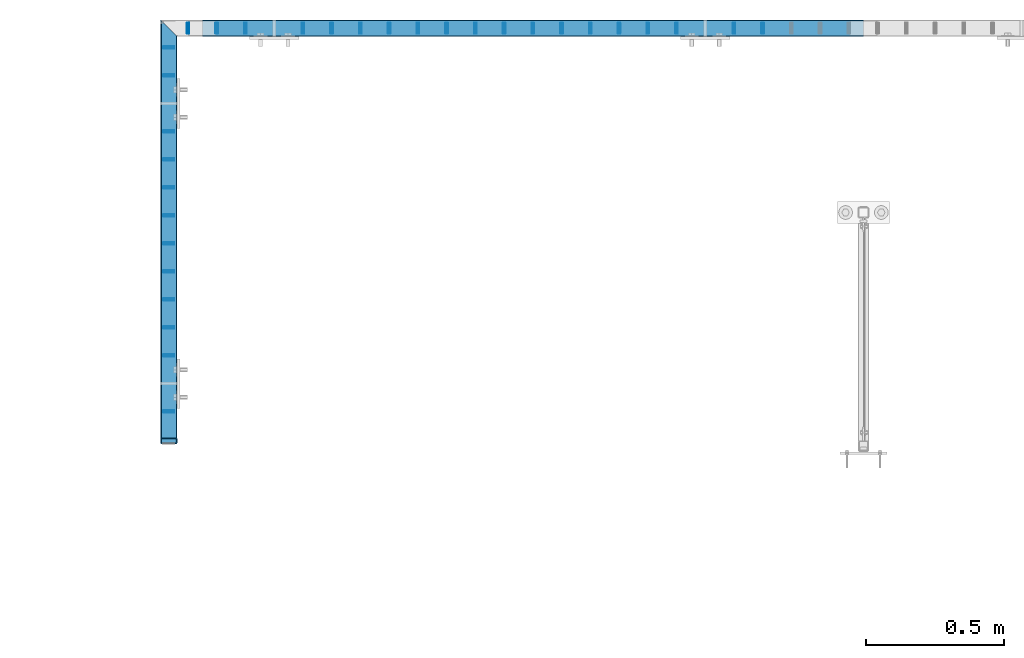
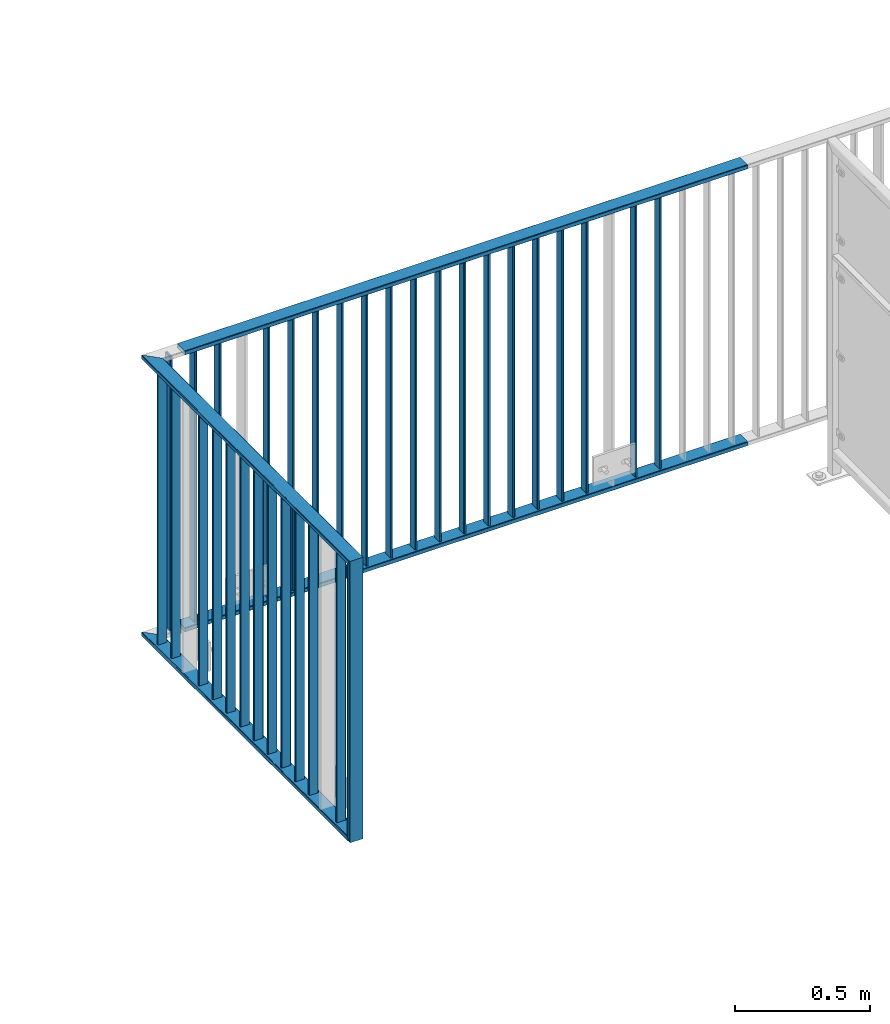
# One storey, part 14 of 156: 36 beams, 2 elements without a shape of their own.
"""IFC2X3 building model written with IfcOpenShell, lengths in millimetres."""

from ifc_helpers import new_model, si_unit, frame, origin_with_axes, origin_2d_with_axis, place, context, subcontext, project, spatial, hollow_rectangle, extrude, clip, halfspace, material, type_object, element, aggregate, save


model = new_model("IFC2X3")

# Units and contexts
model_context = context("Model", 3, precision=1e-05, world=origin_with_axes())
body_context = subcontext(model_context, "Body", "Model", "MODEL_VIEW")
ifc_project = project(units=[si_unit("LENGTHUNIT", "METRE", prefix="MILLI"), si_unit("AREAUNIT", "SQUARE_METRE"), si_unit("VOLUMEUNIT", "CUBIC_METRE"), si_unit("MASSUNIT", "GRAM", prefix="KILO"), si_unit("TIMEUNIT", "SECOND"), si_unit("PLANEANGLEUNIT", "RADIAN"), si_unit("SOLIDANGLEUNIT", "STERADIAN"), si_unit("THERMODYNAMICTEMPERATUREUNIT", "DEGREE_CELSIUS"), si_unit("LUMINOUSINTENSITYUNIT", "LUMEN")], contexts=[model_context])

# Site, building, storey
site_placement = place(None, origin_with_axes())
site = spatial("IfcSite", under=ifc_project, at=site_placement, CompositionType="ELEMENT")
building_placement = place(site_placement, origin_with_axes())
building = spatial("IfcBuilding", under=site, at=building_placement, Name="Undefined", CompositionType="ELEMENT")
storey_placement = place(building_placement, origin_with_axes())
storey = spatial("IfcBuildingStorey", under=building, at=storey_placement, Name="Undefined", CompositionType="ELEMENT", Elevation=0.0)

# Assembly, beam
assembly_1_placement = place(storey_placement, origin_with_axes())
assembly_1 = element("IfcElementAssembly", 1, at=assembly_1_placement, inside=storey, AssemblyPlace="NOTDEFINED", PredefinedType="RIGID_FRAME")
ifc_material = material(Name="STEEL/S235JR")
beam_type_1 = type_object("IfcBeamType", Name="K60/20/2", PredefinedType="NOTDEFINED")
beam_1_placement = place(assembly_1_placement, frame((24399.9535961914, 24057.9916132584, 2740.0), z_axis=(0.0, -1.0, 0.0), x_axis=(-1.0, 0.0, 0.0)))
beam_1 = element("IfcBeam", 2, at=beam_1_placement, type_object=beam_type_1, material=ifc_material, ObjectType="K60/20/2", context=body_context, shape_type="SweptSolid", body=[
    extrude(hollow_rectangle(XDim=20.0, YDim=60.0, WallThickness=2.0, InnerFilletRadius=2.0, OuterFilletRadius=4.0, at=origin_2d_with_axis()), frame((2402.81, 0.0, 0.0), z_axis=(-1.0, 0.0, 0.0), x_axis=(0.0, -1.0, 0.0)), (0.0, 0.0, 1.0), 2402.81),
])

# Assembly, beams
assembly_2_placement = place(storey_placement, origin_with_axes())
assembly_2 = element("IfcElementAssembly", 3, at=assembly_2_placement, inside=storey, AssemblyPlace="NOTDEFINED", PredefinedType="RIGID_FRAME")
beam_2_placement = place(assembly_2_placement, frame((21875.0005187988, 22558.0012658527, 4000.0), z_axis=(1.0, 0.0, 0.0), x_axis=(0.0, 0.0, -1.0)))
beam_2 = element("IfcBeam", 4, at=beam_2_placement, type_object=beam_type_1, material=ifc_material, ObjectType="K60/20/2", context=body_context, shape_type="Clipping", body=[
    clip(clip(extrude(hollow_rectangle(XDim=20.0, YDim=60.0, WallThickness=2.0, InnerFilletRadius=2.0, OuterFilletRadius=4.0, at=origin_2d_with_axis()), frame((1280.2, 0.0, 0.0), z_axis=(-1.0, 0.0, 0.0), x_axis=(0.0, -1.0, 0.0)), (0.0, 0.0, 1.0), 1290.4), halfspace(frame((1270.0, -10.0, 0.0), z_axis=(0.707106781186548, 0.707106781186548, 0.0), x_axis=(0.0, 0.0, 1.0)), False)), halfspace(frame((20.0, 10.0, 0.0), z_axis=(-0.707106781186548, 0.707106781186548, 0.0), x_axis=(0.0, 0.0, 1.0)), False)),
])
beam_3_placement = place(assembly_2_placement, frame((21874.9983520508, 24031.4403835157, 2740.0), z_axis=(1.0, 0.0, 0.0), x_axis=(0.0, -1.0, 0.0)))
beam_3 = element("IfcBeam", 5, at=beam_3_placement, type_object=beam_type_1, material=ifc_material, ObjectType="K60/20/2", context=body_context, shape_type="Clipping", body=[
    clip(clip(extrude(hollow_rectangle(XDim=20.0, YDim=60.0, WallThickness=2.0, InnerFilletRadius=2.0, OuterFilletRadius=4.0, at=origin_2d_with_axis()), frame((1513.83911766303, 0.0, 0.0), z_axis=(-1.0, 0.0, 0.0), x_axis=(0.0, -1.0, 0.0)), (0.0, 0.0, 1.0), 1580.79), halfspace(frame((1483.43911766303, 10.0, 0.002166748046875), z_axis=(-0.707106781186548, 0.707106781186548, 0.0), x_axis=(0.0, 0.0, 1.0)), True)), halfspace(frame((3.44877025730966, 0.0, 30.0), z_axis=(-0.707106781186548, 0.0, 0.707106781186548), x_axis=(0.0, -1.0, 0.0)), False)),
])

# Beam
beam_4_placement = place(assembly_1_placement, frame((24399.9535961914, 24057.9916132584, 3990.0), z_axis=(0.0, -1.0, 0.0), x_axis=(-1.0, 0.0, 0.0)))
beam_4 = element("IfcBeam", 6, at=beam_4_placement, type_object=beam_type_1, material=ifc_material, ObjectType="K60/20/2", context=body_context, shape_type="SweptSolid", body=[
    extrude(hollow_rectangle(XDim=20.0, YDim=60.0, WallThickness=2.0, InnerFilletRadius=2.0, OuterFilletRadius=4.0, at=origin_2d_with_axis()), frame((2402.81, 0.0, 0.0), z_axis=(-1.0, 0.0, 0.0), x_axis=(0.0, -1.0, 0.0)), (0.0, 0.0, 1.0), 2402.81),
])

beam_5_placement = place(assembly_2_placement, frame((21874.9983520508, 24031.4403835157, 3990.0), z_axis=(1.0, 0.0, 0.0), x_axis=(0.0, -1.0, 0.0)))
beam_5 = element("IfcBeam", 7, at=beam_5_placement, type_object=beam_type_1, material=ifc_material, ObjectType="K60/20/2", context=body_context, shape_type="Clipping", body=[
    clip(clip(extrude(hollow_rectangle(XDim=20.0, YDim=60.0, WallThickness=2.0, InnerFilletRadius=2.0, OuterFilletRadius=4.0, at=origin_2d_with_axis()), frame((1513.83911766303, 0.0, 0.0), z_axis=(-1.0, 0.0, 0.0), x_axis=(0.0, -1.0, 0.0)), (0.0, 0.0, 1.0), 1580.79), halfspace(frame((1463.43911766303, 10.0, 0.002166748046875), z_axis=(-0.707106781186548, -0.707106781186548, 0.0), x_axis=(0.0, 0.0, 1.0)), True)), halfspace(frame((-56.5512297426903, 0.0, -30.0), z_axis=(0.707106781186548, 0.0, -0.707106781186548), x_axis=(0.0, -1.0, 0.0)), True)),
])

beam_type_2 = type_object("IfcBeamType", Name="K40/10/1.5", PredefinedType="NOTDEFINED")
beam_6_placement = place(assembly_2_placement, frame((21874.9983597497, 22664.8503835168, 3980.00000000003), z_axis=(1.0, 0.0, 0.0), x_axis=(0.0, 0.0, -1.0)))
beam_6 = element("IfcBeam", 8, at=beam_6_placement, type_object=beam_type_2, material=ifc_material, ObjectType="K40/10/1.5", context=body_context, shape_type="Clipping", body=[
    clip(clip(extrude(hollow_rectangle(XDim=10.0, YDim=40.0, WallThickness=1.5, InnerFilletRadius=1.5, OuterFilletRadius=3.0, at=origin_2d_with_axis()), frame((1237.00000000003, 0.0, 0.0), z_axis=(-1.0, 0.0, 0.0), x_axis=(0.0, -1.0, 0.0)), (0.0, 0.0, 1.0), 1244.0), halfspace(frame((1237.00000000003, 3.63803898150218, 46.7940496082883), z_axis=(1.0, 0.0, 0.0), x_axis=(0.0, -0.758923924280425, -0.65117929724063)), False)), halfspace(frame((-6.99999999997453, -3.63803898149854, 46.7940496082956), z_axis=(-1.0, 0.0, 0.0), x_axis=(0.0, 0.75892392428044, -0.651179297240612)), False)),
])

beam_7_placement = place(assembly_2_placement, frame((21874.9983597497, 22868.4103835168, 3980.00000000003), z_axis=(1.0, 0.0, 0.0), x_axis=(0.0, 0.0, -1.0)))
beam_7 = element("IfcBeam", 9, at=beam_7_placement, type_object=beam_type_2, material=ifc_material, ObjectType="K40/10/1.5", context=body_context, shape_type="Clipping", body=[
    clip(clip(extrude(hollow_rectangle(XDim=10.0, YDim=40.0, WallThickness=1.5, InnerFilletRadius=1.5, OuterFilletRadius=3.0, at=origin_2d_with_axis()), frame((1237.00000000003, 0.0, 0.0), z_axis=(-1.0, 0.0, 0.0), x_axis=(0.0, -1.0, 0.0)), (0.0, 0.0, 1.0), 1244.0), halfspace(frame((1237.00000000003, 3.63803898150218, 46.7940496082883), z_axis=(1.0, 0.0, 0.0), x_axis=(0.0, -0.758923924280425, -0.65117929724063)), False)), halfspace(frame((-6.99999999997453, -3.63803898149854, 46.7940496082956), z_axis=(-1.0, 0.0, 0.0), x_axis=(0.0, 0.75892392428044, -0.651179297240612)), False)),
])

beam_8_placement = place(assembly_2_placement, frame((21874.9983597497, 22970.1903835168, 3980.00000000003), z_axis=(1.0, 0.0, 0.0), x_axis=(0.0, 0.0, -1.0)))
beam_8 = element("IfcBeam", 10, at=beam_8_placement, type_object=beam_type_2, material=ifc_material, ObjectType="K40/10/1.5", context=body_context, shape_type="Clipping", body=[
    clip(clip(extrude(hollow_rectangle(XDim=10.0, YDim=40.0, WallThickness=1.5, InnerFilletRadius=1.5, OuterFilletRadius=3.0, at=origin_2d_with_axis()), frame((1237.00000000003, 0.0, 0.0), z_axis=(-1.0, 0.0, 0.0), x_axis=(0.0, -1.0, 0.0)), (0.0, 0.0, 1.0), 1244.0), halfspace(frame((1237.00000000003, 3.63803898150218, 46.7940496082883), z_axis=(1.0, 0.0, 0.0), x_axis=(0.0, -0.758923924280425, -0.65117929724063)), False)), halfspace(frame((-6.99999999997453, -3.63803898149854, 46.7940496082956), z_axis=(-1.0, 0.0, 0.0), x_axis=(0.0, 0.75892392428044, -0.651179297240612)), False)),
])

beam_9_placement = place(assembly_2_placement, frame((21874.9983597497, 23071.9703835168, 3980.00000000003), z_axis=(1.0, 0.0, 0.0), x_axis=(0.0, 0.0, -1.0)))
beam_9 = element("IfcBeam", 11, at=beam_9_placement, type_object=beam_type_2, material=ifc_material, ObjectType="K40/10/1.5", context=body_context, shape_type="Clipping", body=[
    clip(clip(extrude(hollow_rectangle(XDim=10.0, YDim=40.0, WallThickness=1.5, InnerFilletRadius=1.5, OuterFilletRadius=3.0, at=origin_2d_with_axis()), frame((1237.00000000003, 0.0, 0.0), z_axis=(-1.0, 0.0, 0.0), x_axis=(0.0, -1.0, 0.0)), (0.0, 0.0, 1.0), 1244.0), halfspace(frame((1237.00000000003, 3.63803898150218, 46.7940496082883), z_axis=(1.0, 0.0, 0.0), x_axis=(0.0, -0.758923924280425, -0.65117929724063)), False)), halfspace(frame((-6.99999999997453, -3.63803898149854, 46.7940496082956), z_axis=(-1.0, 0.0, 0.0), x_axis=(0.0, 0.75892392428044, -0.651179297240612)), False)),
])

beam_10_placement = place(assembly_2_placement, frame((21874.9983597497, 23173.7503835168, 3980.00000000003), z_axis=(1.0, 0.0, 0.0), x_axis=(0.0, 0.0, -1.0)))
beam_10 = element("IfcBeam", 12, at=beam_10_placement, type_object=beam_type_2, material=ifc_material, ObjectType="K40/10/1.5", context=body_context, shape_type="Clipping", body=[
    clip(clip(extrude(hollow_rectangle(XDim=10.0, YDim=40.0, WallThickness=1.5, InnerFilletRadius=1.5, OuterFilletRadius=3.0, at=origin_2d_with_axis()), frame((1237.00000000003, 0.0, 0.0), z_axis=(-1.0, 0.0, 0.0), x_axis=(0.0, -1.0, 0.0)), (0.0, 0.0, 1.0), 1244.0), halfspace(frame((1237.00000000003, 3.63803898150218, 46.7940496082883), z_axis=(1.0, 0.0, 0.0), x_axis=(0.0, -0.758923924280425, -0.65117929724063)), False)), halfspace(frame((-6.99999999997453, -3.63803898149854, 46.7940496082956), z_axis=(-1.0, 0.0, 0.0), x_axis=(0.0, 0.75892392428044, -0.651179297240612)), False)),
])

beam_11_placement = place(assembly_2_placement, frame((21874.9983597497, 23275.5303835168, 3980.00000000003), z_axis=(1.0, 0.0, 0.0), x_axis=(0.0, 0.0, -1.0)))
beam_11 = element("IfcBeam", 13, at=beam_11_placement, type_object=beam_type_2, material=ifc_material, ObjectType="K40/10/1.5", context=body_context, shape_type="Clipping", body=[
    clip(clip(extrude(hollow_rectangle(XDim=10.0, YDim=40.0, WallThickness=1.5, InnerFilletRadius=1.5, OuterFilletRadius=3.0, at=origin_2d_with_axis()), frame((1237.00000000003, 0.0, 0.0), z_axis=(-1.0, 0.0, 0.0), x_axis=(0.0, -1.0, 0.0)), (0.0, 0.0, 1.0), 1244.0), halfspace(frame((1237.00000000003, 3.63803898150218, 46.7940496082883), z_axis=(1.0, 0.0, 0.0), x_axis=(0.0, -0.758923924280425, -0.65117929724063)), False)), halfspace(frame((-6.99999999997453, -3.63803898149854, 46.7940496082956), z_axis=(-1.0, 0.0, 0.0), x_axis=(0.0, 0.75892392428044, -0.651179297240612)), False)),
])

beam_12_placement = place(assembly_2_placement, frame((21874.9983597497, 23377.3103835168, 3980.00000000003), z_axis=(1.0, 0.0, 0.0), x_axis=(0.0, 0.0, -1.0)))
beam_12 = element("IfcBeam", 14, at=beam_12_placement, type_object=beam_type_2, material=ifc_material, ObjectType="K40/10/1.5", context=body_context, shape_type="Clipping", body=[
    clip(clip(extrude(hollow_rectangle(XDim=10.0, YDim=40.0, WallThickness=1.5, InnerFilletRadius=1.5, OuterFilletRadius=3.0, at=origin_2d_with_axis()), frame((1237.00000000003, 0.0, 0.0), z_axis=(-1.0, 0.0, 0.0), x_axis=(0.0, -1.0, 0.0)), (0.0, 0.0, 1.0), 1244.0), halfspace(frame((1237.00000000003, 3.63803898150218, 46.7940496082883), z_axis=(1.0, 0.0, 0.0), x_axis=(0.0, -0.758923924280425, -0.65117929724063)), False)), halfspace(frame((-6.99999999997453, -3.63803898149854, 46.7940496082956), z_axis=(-1.0, 0.0, 0.0), x_axis=(0.0, 0.75892392428044, -0.651179297240612)), False)),
])

beam_13_placement = place(assembly_2_placement, frame((21874.9983597497, 23479.0903835168, 3980.00000000003), z_axis=(1.0, 0.0, 0.0), x_axis=(0.0, 0.0, -1.0)))
beam_13 = element("IfcBeam", 15, at=beam_13_placement, type_object=beam_type_2, material=ifc_material, ObjectType="K40/10/1.5", context=body_context, shape_type="Clipping", body=[
    clip(clip(extrude(hollow_rectangle(XDim=10.0, YDim=40.0, WallThickness=1.5, InnerFilletRadius=1.5, OuterFilletRadius=3.0, at=origin_2d_with_axis()), frame((1237.00000000003, 0.0, 0.0), z_axis=(-1.0, 0.0, 0.0), x_axis=(0.0, -1.0, 0.0)), (0.0, 0.0, 1.0), 1244.0), halfspace(frame((1237.00000000003, 3.63803898150218, 46.7940496082883), z_axis=(1.0, 0.0, 0.0), x_axis=(0.0, -0.758923924280425, -0.65117929724063)), False)), halfspace(frame((-6.99999999997453, -3.63803898149854, 46.7940496082956), z_axis=(-1.0, 0.0, 0.0), x_axis=(0.0, 0.75892392428044, -0.651179297240612)), False)),
])

beam_14_placement = place(assembly_2_placement, frame((21874.9983597497, 23580.8703835168, 3980.00000000003), z_axis=(1.0, 0.0, 0.0), x_axis=(0.0, 0.0, -1.0)))
beam_14 = element("IfcBeam", 16, at=beam_14_placement, type_object=beam_type_2, material=ifc_material, ObjectType="K40/10/1.5", context=body_context, shape_type="Clipping", body=[
    clip(clip(extrude(hollow_rectangle(XDim=10.0, YDim=40.0, WallThickness=1.5, InnerFilletRadius=1.5, OuterFilletRadius=3.0, at=origin_2d_with_axis()), frame((1237.00000000003, 0.0, 0.0), z_axis=(-1.0, 0.0, 0.0), x_axis=(0.0, -1.0, 0.0)), (0.0, 0.0, 1.0), 1244.0), halfspace(frame((1237.00000000003, 3.63803898150218, 46.7940496082883), z_axis=(1.0, 0.0, 0.0), x_axis=(0.0, -0.758923924280425, -0.65117929724063)), False)), halfspace(frame((-6.99999999997453, -3.63803898149854, 46.7940496082956), z_axis=(-1.0, 0.0, 0.0), x_axis=(0.0, 0.75892392428044, -0.651179297240612)), False)),
])

beam_15_placement = place(assembly_2_placement, frame((21874.9983597497, 23682.6503835168, 3980.00000000003), z_axis=(1.0, 0.0, 0.0), x_axis=(0.0, 0.0, -1.0)))
beam_15 = element("IfcBeam", 17, at=beam_15_placement, type_object=beam_type_2, material=ifc_material, ObjectType="K40/10/1.5", context=body_context, shape_type="Clipping", body=[
    clip(clip(extrude(hollow_rectangle(XDim=10.0, YDim=40.0, WallThickness=1.5, InnerFilletRadius=1.5, OuterFilletRadius=3.0, at=origin_2d_with_axis()), frame((1237.00000000003, 0.0, 0.0), z_axis=(-1.0, 0.0, 0.0), x_axis=(0.0, -1.0, 0.0)), (0.0, 0.0, 1.0), 1244.0), halfspace(frame((1237.00000000003, 3.63803898150218, 46.7940496082883), z_axis=(1.0, 0.0, 0.0), x_axis=(0.0, -0.758923924280425, -0.65117929724063)), False)), halfspace(frame((-6.99999999997453, -3.63803898149854, 46.7940496082956), z_axis=(-1.0, 0.0, 0.0), x_axis=(0.0, 0.75892392428044, -0.651179297240612)), False)),
])

beam_16_placement = place(assembly_1_placement, frame((22153.8485961914, 24057.9916132584, 3980.00000000003), z_axis=(0.0, -1.0, 0.0), x_axis=(0.0, 0.0, -1.0)))
beam_16 = element("IfcBeam", 18, at=beam_16_placement, type_object=beam_type_2, material=ifc_material, ObjectType="K40/10/1.5", context=body_context, shape_type="Clipping", body=[
    clip(clip(extrude(hollow_rectangle(XDim=10.0, YDim=40.0, WallThickness=1.5, InnerFilletRadius=1.5, OuterFilletRadius=3.0, at=origin_2d_with_axis()), frame((1237.00000000003, 0.0, 0.0), z_axis=(-1.0, 0.0, 0.0), x_axis=(0.0, -1.0, 0.0)), (0.0, 0.0, 1.0), 1244.0), halfspace(frame((1237.00000000003, 4.34248751949781, 47.3810900558092), z_axis=(1.0, 0.0, 0.0), x_axis=(0.0, -0.768354814194188, -0.640024124158313)), False)), halfspace(frame((-6.99999999997453, -4.34248751950508, 47.3810900558092), z_axis=(-1.0, 0.0, 0.0), x_axis=(0.0, 0.7683548141934, -0.640024124159258)), False)),
])

beam_17_placement = place(assembly_1_placement, frame((23720.8985961914, 24057.9916132584, 3980.00000000003), z_axis=(0.0, -1.0, 0.0), x_axis=(0.0, 0.0, -1.0)))
beam_17 = element("IfcBeam", 19, at=beam_17_placement, type_object=beam_type_2, material=ifc_material, ObjectType="K40/10/1.5", context=body_context, shape_type="Clipping", body=[
    clip(clip(extrude(hollow_rectangle(XDim=10.0, YDim=40.0, WallThickness=1.5, InnerFilletRadius=1.5, OuterFilletRadius=3.0, at=origin_2d_with_axis()), frame((1237.00000000003, 0.0, 0.0), z_axis=(-1.0, 0.0, 0.0), x_axis=(0.0, -1.0, 0.0)), (0.0, 0.0, 1.0), 1244.0), halfspace(frame((1237.00000000003, 4.34248751949781, 47.3810900558092), z_axis=(1.0, 0.0, 0.0), x_axis=(0.0, -0.768354814194188, -0.640024124158313)), False)), halfspace(frame((-6.99999999997453, -4.34248751950508, 47.3810900558092), z_axis=(-1.0, 0.0, 0.0), x_axis=(0.0, 0.7683548141934, -0.640024124159258)), False)),
])

beam_18_placement = place(assembly_1_placement, frame((22049.3785961914, 24057.9916132584, 3980.00000000003), z_axis=(0.0, -1.0, 0.0), x_axis=(0.0, 0.0, -1.0)))
beam_18 = element("IfcBeam", 20, at=beam_18_placement, type_object=beam_type_2, material=ifc_material, ObjectType="K40/10/1.5", context=body_context, shape_type="Clipping", body=[
    clip(clip(extrude(hollow_rectangle(XDim=10.0, YDim=40.0, WallThickness=1.5, InnerFilletRadius=1.5, OuterFilletRadius=3.0, at=origin_2d_with_axis()), frame((1237.00000000003, 0.0, 0.0), z_axis=(-1.0, 0.0, 0.0), x_axis=(0.0, -1.0, 0.0)), (0.0, 0.0, 1.0), 1244.0), halfspace(frame((1237.00000000003, 4.34248751949781, 47.3810900558092), z_axis=(1.0, 0.0, 0.0), x_axis=(0.0, -0.763991285051099, -0.645226562043109)), False)), halfspace(frame((-6.99999999997453, -4.34248751950508, 47.3810900558092), z_axis=(-1.0, 0.0, 0.0), x_axis=(0.0, 0.763991285051099, -0.645226562043109)), False)),
])

beam_19_placement = place(assembly_1_placement, frame((22362.7885961914, 24057.9916132584, 3980.00000000003), z_axis=(0.0, -1.0, 0.0), x_axis=(0.0, 0.0, -1.0)))
beam_19 = element("IfcBeam", 21, at=beam_19_placement, type_object=beam_type_2, material=ifc_material, ObjectType="K40/10/1.5", context=body_context, shape_type="Clipping", body=[
    clip(clip(extrude(hollow_rectangle(XDim=10.0, YDim=40.0, WallThickness=1.5, InnerFilletRadius=1.5, OuterFilletRadius=3.0, at=origin_2d_with_axis()), frame((1237.00000000003, 0.0, 0.0), z_axis=(-1.0, 0.0, 0.0), x_axis=(0.0, -1.0, 0.0)), (0.0, 0.0, 1.0), 1244.0), halfspace(frame((1237.00000000003, 4.34248751949781, 47.3810900558092), z_axis=(1.0, 0.0, 0.0), x_axis=(0.0, -0.768354814194188, -0.640024124158313)), False)), halfspace(frame((-6.99999999997453, -4.34248751950508, 47.3810900558092), z_axis=(-1.0, 0.0, 0.0), x_axis=(0.0, 0.7683548141934, -0.640024124159258)), False)),
])

beam_20_placement = place(assembly_1_placement, frame((22467.2585961914, 24057.9916132584, 3980.00000000003), z_axis=(0.0, -1.0, 0.0), x_axis=(0.0, 0.0, -1.0)))
beam_20 = element("IfcBeam", 22, at=beam_20_placement, type_object=beam_type_2, material=ifc_material, ObjectType="K40/10/1.5", context=body_context, shape_type="Clipping", body=[
    clip(clip(extrude(hollow_rectangle(XDim=10.0, YDim=40.0, WallThickness=1.5, InnerFilletRadius=1.5, OuterFilletRadius=3.0, at=origin_2d_with_axis()), frame((1237.00000000003, 0.0, 0.0), z_axis=(-1.0, 0.0, 0.0), x_axis=(0.0, -1.0, 0.0)), (0.0, 0.0, 1.0), 1244.0), halfspace(frame((1237.00000000003, 4.34248751949781, 47.3810900558092), z_axis=(1.0, 0.0, 0.0), x_axis=(0.0, -0.768354814194188, -0.640024124158313)), False)), halfspace(frame((-6.99999999997453, -4.34248751950508, 47.3810900558092), z_axis=(-1.0, 0.0, 0.0), x_axis=(0.0, 0.7683548141934, -0.640024124159258)), False)),
])

beam_21_placement = place(assembly_1_placement, frame((22571.7285961914, 24057.9916132584, 3980.00000000003), z_axis=(0.0, -1.0, 0.0), x_axis=(0.0, 0.0, -1.0)))
beam_21 = element("IfcBeam", 23, at=beam_21_placement, type_object=beam_type_2, material=ifc_material, ObjectType="K40/10/1.5", context=body_context, shape_type="Clipping", body=[
    clip(clip(extrude(hollow_rectangle(XDim=10.0, YDim=40.0, WallThickness=1.5, InnerFilletRadius=1.5, OuterFilletRadius=3.0, at=origin_2d_with_axis()), frame((1237.00000000003, 0.0, 0.0), z_axis=(-1.0, 0.0, 0.0), x_axis=(0.0, -1.0, 0.0)), (0.0, 0.0, 1.0), 1244.0), halfspace(frame((1237.00000000003, 4.34248751949781, 47.3810900558092), z_axis=(1.0, 0.0, 0.0), x_axis=(0.0, -0.768354814194188, -0.640024124158313)), False)), halfspace(frame((-6.99999999997453, -4.34248751950508, 47.3810900558092), z_axis=(-1.0, 0.0, 0.0), x_axis=(0.0, 0.7683548141934, -0.640024124159258)), False)),
])

beam_22_placement = place(assembly_1_placement, frame((22676.1985961914, 24057.9916132584, 3980.00000000003), z_axis=(0.0, -1.0, 0.0), x_axis=(0.0, 0.0, -1.0)))
beam_22 = element("IfcBeam", 24, at=beam_22_placement, type_object=beam_type_2, material=ifc_material, ObjectType="K40/10/1.5", context=body_context, shape_type="Clipping", body=[
    clip(clip(extrude(hollow_rectangle(XDim=10.0, YDim=40.0, WallThickness=1.5, InnerFilletRadius=1.5, OuterFilletRadius=3.0, at=origin_2d_with_axis()), frame((1237.00000000003, 0.0, 0.0), z_axis=(-1.0, 0.0, 0.0), x_axis=(0.0, -1.0, 0.0)), (0.0, 0.0, 1.0), 1244.0), halfspace(frame((1237.00000000003, 4.34248751949781, 47.3810900558092), z_axis=(1.0, 0.0, 0.0), x_axis=(0.0, -0.768354814194188, -0.640024124158313)), False)), halfspace(frame((-6.99999999997453, -4.34248751950508, 47.3810900558092), z_axis=(-1.0, 0.0, 0.0), x_axis=(0.0, 0.7683548141934, -0.640024124159258)), False)),
])

beam_23_placement = place(assembly_1_placement, frame((22780.6685961914, 24057.9916132584, 3980.00000000003), z_axis=(0.0, -1.0, 0.0), x_axis=(0.0, 0.0, -1.0)))
beam_23 = element("IfcBeam", 25, at=beam_23_placement, type_object=beam_type_2, material=ifc_material, ObjectType="K40/10/1.5", context=body_context, shape_type="Clipping", body=[
    clip(clip(extrude(hollow_rectangle(XDim=10.0, YDim=40.0, WallThickness=1.5, InnerFilletRadius=1.5, OuterFilletRadius=3.0, at=origin_2d_with_axis()), frame((1237.00000000003, 0.0, 0.0), z_axis=(-1.0, 0.0, 0.0), x_axis=(0.0, -1.0, 0.0)), (0.0, 0.0, 1.0), 1244.0), halfspace(frame((1237.00000000003, 4.34248751949781, 47.3810900558092), z_axis=(1.0, 0.0, 0.0), x_axis=(0.0, -0.768354814194188, -0.640024124158313)), False)), halfspace(frame((-6.99999999997453, -4.34248751950508, 47.3810900558092), z_axis=(-1.0, 0.0, 0.0), x_axis=(0.0, 0.7683548141934, -0.640024124159258)), False)),
])

beam_24_placement = place(assembly_1_placement, frame((22885.1385961914, 24057.9916132584, 3980.00000000003), z_axis=(0.0, -1.0, 0.0), x_axis=(0.0, 0.0, -1.0)))
beam_24 = element("IfcBeam", 26, at=beam_24_placement, type_object=beam_type_2, material=ifc_material, ObjectType="K40/10/1.5", context=body_context, shape_type="Clipping", body=[
    clip(clip(extrude(hollow_rectangle(XDim=10.0, YDim=40.0, WallThickness=1.5, InnerFilletRadius=1.5, OuterFilletRadius=3.0, at=origin_2d_with_axis()), frame((1237.00000000003, 0.0, 0.0), z_axis=(-1.0, 0.0, 0.0), x_axis=(0.0, -1.0, 0.0)), (0.0, 0.0, 1.0), 1244.0), halfspace(frame((1237.00000000003, 4.34248751949781, 47.3810900558092), z_axis=(1.0, 0.0, 0.0), x_axis=(0.0, -0.768354814194188, -0.640024124158313)), False)), halfspace(frame((-6.99999999997453, -4.34248751950508, 47.3810900558092), z_axis=(-1.0, 0.0, 0.0), x_axis=(0.0, 0.7683548141934, -0.640024124159258)), False)),
])

beam_25_placement = place(assembly_1_placement, frame((22989.6085961914, 24057.9916132584, 3980.00000000003), z_axis=(0.0, -1.0, 0.0), x_axis=(0.0, 0.0, -1.0)))
beam_25 = element("IfcBeam", 27, at=beam_25_placement, type_object=beam_type_2, material=ifc_material, ObjectType="K40/10/1.5", context=body_context, shape_type="Clipping", body=[
    clip(clip(extrude(hollow_rectangle(XDim=10.0, YDim=40.0, WallThickness=1.5, InnerFilletRadius=1.5, OuterFilletRadius=3.0, at=origin_2d_with_axis()), frame((1237.00000000003, 0.0, 0.0), z_axis=(-1.0, 0.0, 0.0), x_axis=(0.0, -1.0, 0.0)), (0.0, 0.0, 1.0), 1244.0), halfspace(frame((1237.00000000003, 4.34248751949781, 47.3810900558092), z_axis=(1.0, 0.0, 0.0), x_axis=(0.0, -0.768354814194188, -0.640024124158313)), False)), halfspace(frame((-6.99999999997453, -4.34248751950508, 47.3810900558092), z_axis=(-1.0, 0.0, 0.0), x_axis=(0.0, 0.7683548141934, -0.640024124159258)), False)),
])

beam_26_placement = place(assembly_1_placement, frame((23094.0785961914, 24057.9916132584, 3980.00000000003), z_axis=(0.0, -1.0, 0.0), x_axis=(0.0, 0.0, -1.0)))
beam_26 = element("IfcBeam", 28, at=beam_26_placement, type_object=beam_type_2, material=ifc_material, ObjectType="K40/10/1.5", context=body_context, shape_type="Clipping", body=[
    clip(clip(extrude(hollow_rectangle(XDim=10.0, YDim=40.0, WallThickness=1.5, InnerFilletRadius=1.5, OuterFilletRadius=3.0, at=origin_2d_with_axis()), frame((1237.00000000003, 0.0, 0.0), z_axis=(-1.0, 0.0, 0.0), x_axis=(0.0, -1.0, 0.0)), (0.0, 0.0, 1.0), 1244.0), halfspace(frame((1237.00000000003, 4.34248751949781, 47.3810900558092), z_axis=(1.0, 0.0, 0.0), x_axis=(0.0, -0.768354814194188, -0.640024124158313)), False)), halfspace(frame((-6.99999999997453, -4.34248751950508, 47.3810900558092), z_axis=(-1.0, 0.0, 0.0), x_axis=(0.0, 0.7683548141934, -0.640024124159258)), False)),
])

beam_27_placement = place(assembly_1_placement, frame((23198.5485961914, 24057.9916132584, 3980.00000000003), z_axis=(0.0, -1.0, 0.0), x_axis=(0.0, 0.0, -1.0)))
beam_27 = element("IfcBeam", 29, at=beam_27_placement, type_object=beam_type_2, material=ifc_material, ObjectType="K40/10/1.5", context=body_context, shape_type="Clipping", body=[
    clip(clip(extrude(hollow_rectangle(XDim=10.0, YDim=40.0, WallThickness=1.5, InnerFilletRadius=1.5, OuterFilletRadius=3.0, at=origin_2d_with_axis()), frame((1237.00000000003, 0.0, 0.0), z_axis=(-1.0, 0.0, 0.0), x_axis=(0.0, -1.0, 0.0)), (0.0, 0.0, 1.0), 1244.0), halfspace(frame((1237.00000000003, 4.34248751949781, 47.3810900558092), z_axis=(1.0, 0.0, 0.0), x_axis=(0.0, -0.768354814194188, -0.640024124158313)), False)), halfspace(frame((-6.99999999997453, -4.34248751950508, 47.3810900558092), z_axis=(-1.0, 0.0, 0.0), x_axis=(0.0, 0.7683548141934, -0.640024124159258)), False)),
])

beam_28_placement = place(assembly_1_placement, frame((23303.0185961914, 24057.9916132584, 3980.00000000003), z_axis=(0.0, -1.0, 0.0), x_axis=(0.0, 0.0, -1.0)))
beam_28 = element("IfcBeam", 30, at=beam_28_placement, type_object=beam_type_2, material=ifc_material, ObjectType="K40/10/1.5", context=body_context, shape_type="Clipping", body=[
    clip(clip(extrude(hollow_rectangle(XDim=10.0, YDim=40.0, WallThickness=1.5, InnerFilletRadius=1.5, OuterFilletRadius=3.0, at=origin_2d_with_axis()), frame((1237.00000000003, 0.0, 0.0), z_axis=(-1.0, 0.0, 0.0), x_axis=(0.0, -1.0, 0.0)), (0.0, 0.0, 1.0), 1244.0), halfspace(frame((1237.00000000003, 4.34248751949781, 47.3810900558092), z_axis=(1.0, 0.0, 0.0), x_axis=(0.0, -0.768354814194188, -0.640024124158313)), False)), halfspace(frame((-6.99999999997453, -4.34248751950508, 47.3810900558092), z_axis=(-1.0, 0.0, 0.0), x_axis=(0.0, 0.7683548141934, -0.640024124159258)), False)),
])

beam_29_placement = place(assembly_1_placement, frame((23407.4885961914, 24057.9916132584, 3980.00000000003), z_axis=(0.0, -1.0, 0.0), x_axis=(0.0, 0.0, -1.0)))
beam_29 = element("IfcBeam", 31, at=beam_29_placement, type_object=beam_type_2, material=ifc_material, ObjectType="K40/10/1.5", context=body_context, shape_type="Clipping", body=[
    clip(clip(extrude(hollow_rectangle(XDim=10.0, YDim=40.0, WallThickness=1.5, InnerFilletRadius=1.5, OuterFilletRadius=3.0, at=origin_2d_with_axis()), frame((1237.00000000003, 0.0, 0.0), z_axis=(-1.0, 0.0, 0.0), x_axis=(0.0, -1.0, 0.0)), (0.0, 0.0, 1.0), 1244.0), halfspace(frame((1237.00000000003, 4.34248751949781, 47.3810900558092), z_axis=(1.0, 0.0, 0.0), x_axis=(0.0, -0.768354814194188, -0.640024124158313)), False)), halfspace(frame((-6.99999999997453, -4.34248751950508, 47.3810900558092), z_axis=(-1.0, 0.0, 0.0), x_axis=(0.0, 0.7683548141934, -0.640024124159258)), False)),
])

beam_30_placement = place(assembly_1_placement, frame((23511.9585961914, 24057.9916132584, 3980.00000000003), z_axis=(0.0, -1.0, 0.0), x_axis=(0.0, 0.0, -1.0)))
beam_30 = element("IfcBeam", 32, at=beam_30_placement, type_object=beam_type_2, material=ifc_material, ObjectType="K40/10/1.5", context=body_context, shape_type="Clipping", body=[
    clip(clip(extrude(hollow_rectangle(XDim=10.0, YDim=40.0, WallThickness=1.5, InnerFilletRadius=1.5, OuterFilletRadius=3.0, at=origin_2d_with_axis()), frame((1237.00000000003, 0.0, 0.0), z_axis=(-1.0, 0.0, 0.0), x_axis=(0.0, -1.0, 0.0)), (0.0, 0.0, 1.0), 1244.0), halfspace(frame((1237.00000000003, 4.34248751949781, 47.3810900558092), z_axis=(1.0, 0.0, 0.0), x_axis=(0.0, -0.768354814194188, -0.640024124158313)), False)), halfspace(frame((-6.99999999997453, -4.34248751950508, 47.3810900558092), z_axis=(-1.0, 0.0, 0.0), x_axis=(0.0, 0.7683548141934, -0.640024124159258)), False)),
])

beam_31_placement = place(assembly_1_placement, frame((23616.4285961914, 24057.9916132584, 3980.00000000003), z_axis=(0.0, -1.0, 0.0), x_axis=(0.0, 0.0, -1.0)))
beam_31 = element("IfcBeam", 33, at=beam_31_placement, type_object=beam_type_2, material=ifc_material, ObjectType="K40/10/1.5", context=body_context, shape_type="Clipping", body=[
    clip(clip(extrude(hollow_rectangle(XDim=10.0, YDim=40.0, WallThickness=1.5, InnerFilletRadius=1.5, OuterFilletRadius=3.0, at=origin_2d_with_axis()), frame((1237.00000000003, 0.0, 0.0), z_axis=(-1.0, 0.0, 0.0), x_axis=(0.0, -1.0, 0.0)), (0.0, 0.0, 1.0), 1244.0), halfspace(frame((1237.00000000003, 4.34248751949781, 47.3810900558092), z_axis=(1.0, 0.0, 0.0), x_axis=(0.0, -0.768354814194188, -0.640024124158313)), False)), halfspace(frame((-6.99999999997453, -4.34248751950508, 47.3810900558092), z_axis=(-1.0, 0.0, 0.0), x_axis=(0.0, 0.7683548141934, -0.640024124159258)), False)),
])

beam_32_placement = place(assembly_1_placement, frame((23929.8385961914, 24057.9916132584, 3980.00000000003), z_axis=(0.0, -1.0, 0.0), x_axis=(0.0, 0.0, -1.0)))
beam_32 = element("IfcBeam", 34, at=beam_32_placement, type_object=beam_type_2, material=ifc_material, ObjectType="K40/10/1.5", context=body_context, shape_type="Clipping", body=[
    clip(clip(extrude(hollow_rectangle(XDim=10.0, YDim=40.0, WallThickness=1.5, InnerFilletRadius=1.5, OuterFilletRadius=3.0, at=origin_2d_with_axis()), frame((1237.00000000003, 0.0, 0.0), z_axis=(-1.0, 0.0, 0.0), x_axis=(0.0, -1.0, 0.0)), (0.0, 0.0, 1.0), 1244.0), halfspace(frame((1237.00000000003, 4.34248751949781, 47.3810900558092), z_axis=(1.0, 0.0, 0.0), x_axis=(0.0, -0.768354814194188, -0.640024124158313)), False)), halfspace(frame((-6.99999999997453, -4.34248751950508, 47.3810900558092), z_axis=(-1.0, 0.0, 0.0), x_axis=(0.0, 0.7683548141934, -0.640024124159258)), False)),
])

beam_33_placement = place(assembly_1_placement, frame((24034.3085961914, 24057.9916132584, 3980.00000000003), z_axis=(0.0, -1.0, 0.0), x_axis=(0.0, 0.0, -1.0)))
beam_33 = element("IfcBeam", 35, at=beam_33_placement, type_object=beam_type_2, material=ifc_material, ObjectType="K40/10/1.5", context=body_context, shape_type="Clipping", body=[
    clip(clip(extrude(hollow_rectangle(XDim=10.0, YDim=40.0, WallThickness=1.5, InnerFilletRadius=1.5, OuterFilletRadius=3.0, at=origin_2d_with_axis()), frame((1237.00000000003, 0.0, 0.0), z_axis=(-1.0, 0.0, 0.0), x_axis=(0.0, -1.0, 0.0)), (0.0, 0.0, 1.0), 1244.0), halfspace(frame((1237.00000000003, 4.34248751949781, 47.3810900558092), z_axis=(1.0, 0.0, 0.0), x_axis=(0.0, -0.768354814194188, -0.640024124158313)), False)), halfspace(frame((-6.99999999997453, -4.34248751950508, 47.3810900558092), z_axis=(-1.0, 0.0, 0.0), x_axis=(0.0, 0.7683548141934, -0.640024124159258)), False)),
])

aggregate(assembly_1, [beam_1, beam_16, beam_17, beam_18, beam_19, beam_20, beam_21, beam_22, beam_23, beam_24, beam_25, beam_26, beam_27, beam_28, beam_29, beam_30, beam_31, beam_32, beam_33, beam_4])

beam_34_placement = place(assembly_2_placement, frame((21874.9983597497, 23886.2103835168, 3980.00000000003), z_axis=(1.0, 0.0, 0.0), x_axis=(0.0, 0.0, -1.0)))
beam_34 = element("IfcBeam", 36, at=beam_34_placement, type_object=beam_type_2, material=ifc_material, ObjectType="K40/10/1.5", context=body_context, shape_type="Clipping", body=[
    clip(clip(extrude(hollow_rectangle(XDim=10.0, YDim=40.0, WallThickness=1.5, InnerFilletRadius=1.5, OuterFilletRadius=3.0, at=origin_2d_with_axis()), frame((1237.00000000003, 0.0, 0.0), z_axis=(-1.0, 0.0, 0.0), x_axis=(0.0, -1.0, 0.0)), (0.0, 0.0, 1.0), 1244.0), halfspace(frame((1237.00000000003, 3.2449841921989, 46.4665039507236), z_axis=(1.0, 0.0, 0.0), x_axis=(0.0, -0.754414263122933, -0.656398598106883)), False)), halfspace(frame((-6.99999999997453, -3.24498419219526, 46.4665039507308), z_axis=(-1.0, 0.0, 0.0), x_axis=(0.0, 0.75441426312288, -0.656398598106944)), False)),
])

beam_35_placement = place(assembly_2_placement, frame((21944.998046875, 24057.9916132584, 3980.00000000003), z_axis=(0.0, -1.0, 0.0), x_axis=(0.0, 0.0, -1.0)))
beam_35 = element("IfcBeam", 37, at=beam_35_placement, type_object=beam_type_2, material=ifc_material, ObjectType="K40/10/1.5", context=body_context, shape_type="Clipping", body=[
    clip(clip(extrude(hollow_rectangle(XDim=10.0, YDim=40.0, WallThickness=1.5, InnerFilletRadius=1.5, OuterFilletRadius=3.0, at=origin_2d_with_axis()), frame((1237.00000000003, 0.0, 0.0), z_axis=(-1.0, 0.0, 0.0), x_axis=(0.0, -1.0, 0.0)), (0.0, 0.0, 1.0), 1244.0), halfspace(frame((1237.00000000003, 4.34248751949781, 47.3810900558092), z_axis=(1.0, 0.0, 0.0), x_axis=(0.0, -0.768354814194188, -0.640024124158313)), False)), halfspace(frame((-6.99999999997453, -4.34248751950508, 47.3810900558092), z_axis=(-1.0, 0.0, 0.0), x_axis=(0.0, 0.7683548141934, -0.640024124159258)), False)),
])

beam_36_placement = place(assembly_2_placement, frame((21874.9983597497, 23987.9903835168, 3980.00000000003), z_axis=(1.0, 0.0, 0.0), x_axis=(0.0, 0.0, -1.0)))
beam_36 = element("IfcBeam", 38, at=beam_36_placement, type_object=beam_type_2, material=ifc_material, ObjectType="K40/10/1.5", context=body_context, shape_type="Clipping", body=[
    clip(clip(extrude(hollow_rectangle(XDim=10.0, YDim=40.0, WallThickness=1.5, InnerFilletRadius=1.5, OuterFilletRadius=3.0, at=origin_2d_with_axis()), frame((1237.00000000003, 0.0, 0.0), z_axis=(-1.0, 0.0, 0.0), x_axis=(0.0, -1.0, 0.0)), (0.0, 0.0, 1.0), 1244.0), halfspace(frame((1237.00000000003, 0.531585963377438, 44.2053387614833), z_axis=(1.0, 0.0, 0.0), x_axis=(0.0, -0.72237744111132, -0.691498975106588)), False)), halfspace(frame((-6.99999999997453, -0.5315859633738, 44.2053387614833), z_axis=(-1.0, 0.0, 0.0), x_axis=(0.0, 0.722377441111346, -0.691498975106561)), False)),
])

aggregate(assembly_2, [beam_6, beam_7, beam_8, beam_9, beam_10, beam_11, beam_12, beam_13, beam_14, beam_15, beam_34, beam_35, beam_2, beam_36, beam_3, beam_5])

save(model, "model.ifc")
